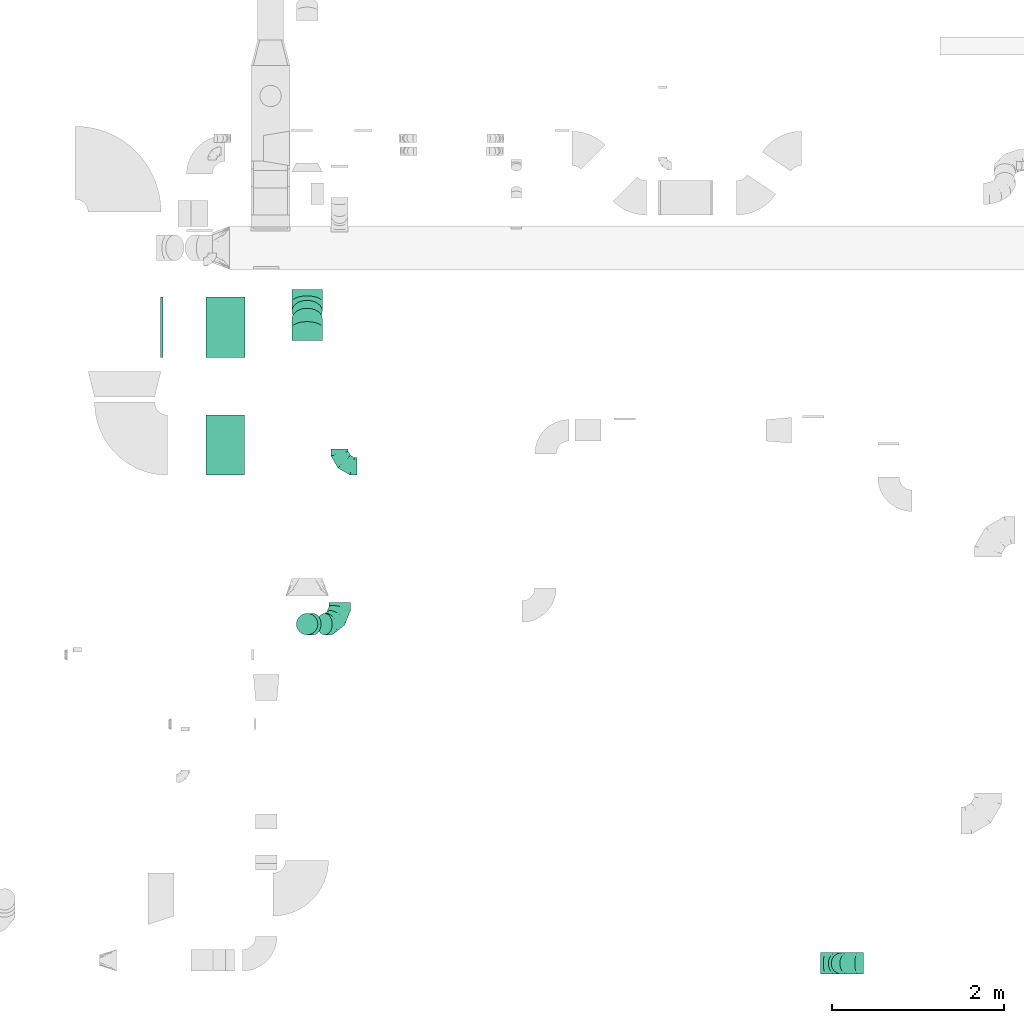
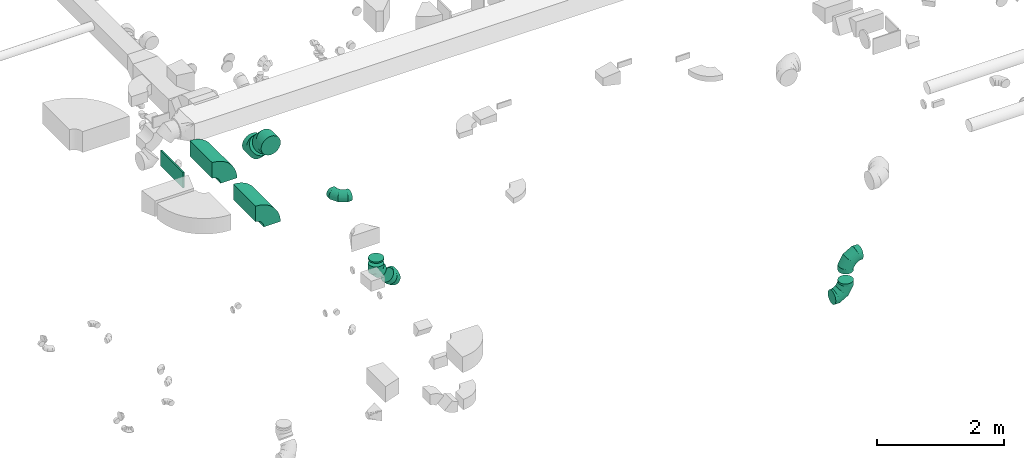
# One storey, part 27 of 62: 11 flow fittings.
"""IFC2X3 building model written with IfcOpenShell, lengths in millimetres."""

from ifc_helpers import new_model, entity, si_unit, converted_unit, derived_unit, direction, frame, frame_2d, origin, origin_2d_with_axis, place, context, subcontext, project, spatial, polyline, circle_curve, parameter, trimmed, segment, composite_curve, rectangle, outline, extrude, faceted_brep, source, transform, mapped, material, type_object, type_shapes, element, save


model = new_model("IFC2X3")

# Units and contexts
model_context = context("Model", 3, precision=0.01, world=origin(), true_north=direction((6.12303176911189e-17, 1.0)))
body_context = subcontext(model_context, "Body", "Model", "MODEL_VIEW")
ifc_project = project(units=[si_unit("LENGTHUNIT", "METRE", prefix="MILLI"), si_unit("AREAUNIT", "SQUARE_METRE"), si_unit("VOLUMEUNIT", "CUBIC_METRE"), converted_unit("PLANEANGLEUNIT", "DEGREE", entity("IfcRatioMeasure", 0.0174532925199433), si_unit("PLANEANGLEUNIT", "RADIAN"), dimensions=[0, 0, 0, 0, 0, 0, 0]), si_unit("MASSUNIT", "GRAM", prefix="KILO"), derived_unit("MASSDENSITYUNIT", [(si_unit("MASSUNIT", "GRAM", prefix="KILO"), 1), (si_unit("LENGTHUNIT", "METRE"), -3)]), derived_unit("MOMENTOFINERTIAUNIT", [(si_unit("LENGTHUNIT", "METRE"), 4)]), si_unit("TIMEUNIT", "SECOND"), si_unit("FREQUENCYUNIT", "HERTZ"), si_unit("THERMODYNAMICTEMPERATUREUNIT", "DEGREE_CELSIUS"), derived_unit("THERMALTRANSMITTANCEUNIT", [(si_unit("MASSUNIT", "GRAM", prefix="KILO"), 1), (si_unit("THERMODYNAMICTEMPERATUREUNIT", "KELVIN"), -1), (si_unit("TIMEUNIT", "SECOND"), -3)]), derived_unit("VOLUMETRICFLOWRATEUNIT", [(si_unit("LENGTHUNIT", "METRE"), 3), (si_unit("TIMEUNIT", "SECOND"), -1)]), derived_unit("MASSFLOWRATEUNIT", [(si_unit("MASSUNIT", "GRAM", prefix="KILO"), 1), (si_unit("TIMEUNIT", "SECOND"), -1)]), derived_unit("ROTATIONALFREQUENCYUNIT", [(si_unit("TIMEUNIT", "SECOND"), -1)]), si_unit("ELECTRICCURRENTUNIT", "AMPERE"), si_unit("ELECTRICVOLTAGEUNIT", "VOLT"), si_unit("POWERUNIT", "WATT"), si_unit("FORCEUNIT", "NEWTON", prefix="KILO"), si_unit("ILLUMINANCEUNIT", "LUX"), si_unit("LUMINOUSFLUXUNIT", "LUMEN"), si_unit("LUMINOUSINTENSITYUNIT", "CANDELA"), derived_unit("USERDEFINED", [(si_unit("MASSUNIT", "GRAM", prefix="KILO"), -1), (si_unit("LENGTHUNIT", "METRE"), -2), (si_unit("TIMEUNIT", "SECOND"), 3), (si_unit("LUMINOUSFLUXUNIT", "LUMEN"), 1)]), derived_unit("LINEARVELOCITYUNIT", [(si_unit("LENGTHUNIT", "METRE"), 1), (si_unit("TIMEUNIT", "SECOND"), -1)]), si_unit("PRESSUREUNIT", "PASCAL"), derived_unit("USERDEFINED", [(si_unit("LENGTHUNIT", "METRE"), -2), (si_unit("MASSUNIT", "GRAM", prefix="KILO"), 1), (si_unit("TIMEUNIT", "SECOND"), -2)]), derived_unit("LINEARFORCEUNIT", [(si_unit("MASSUNIT", "GRAM", prefix="KILO"), 1), (si_unit("LENGTHUNIT", "METRE"), 1), (si_unit("TIMEUNIT", "SECOND"), -2), (si_unit("LENGTHUNIT", "METRE"), -1)]), derived_unit("PLANARFORCEUNIT", [(si_unit("MASSUNIT", "GRAM", prefix="KILO"), 1), (si_unit("LENGTHUNIT", "METRE"), 1), (si_unit("TIMEUNIT", "SECOND"), -2), (si_unit("LENGTHUNIT", "METRE"), -2)])], contexts=[model_context])

# Site, building, storey
site_placement = place(None, origin())
site = spatial("IfcSite", under=ifc_project, at=site_placement, CompositionType="ELEMENT")
building_placement = place(site_placement, origin())
building = spatial("IfcBuilding", under=site, at=building_placement, CompositionType="ELEMENT")
storey_placement = place(building_placement, frame((0.0, 0.0, 24000.0)))
storey = spatial("IfcBuildingStorey", under=building, at=storey_placement, CompositionType="ELEMENT", Elevation=24000.0)

# Flow fittings
ifc_material = material()
duct_fitting_type_1 = type_object("IfcDuctFittingType", PredefinedType="NOTDEFINED", material=ifc_material)
shared_shape_1 = source(origin(), body_context, "Body", "SweptSolid", [
    extrude(rectangle(XDim=26.096000000006, YDim=700.0, at=origin_2d_with_axis()), frame((6.95, 0.0, -150.0)), (0.0, 0.0, 1.0), 300.0),
])
type_shapes(duct_fitting_type_1, [shared_shape_1])
flow_fitting_1_placement = place(storey_placement, frame((38820.62, 8000.31, 3550.0), z_axis=(0.0, 0.0, -1.0), x_axis=(1.0, 0.0, 0.0)))
element("IfcFlowFitting", 1, at=flow_fitting_1_placement, inside=storey, type_object=duct_fitting_type_1, material=ifc_material, context=body_context, shape_type="MappedRepresentation", body=[
    mapped(shared_shape_1, transform((0.0, 0.0, 0.0), scale=1.0)),
])
duct_fitting_type_2 = type_object("IfcDuctFittingType", PredefinedType="NOTDEFINED", material=ifc_material)
shared_shape_2 = source(origin(), body_context, "Body", "Brep", [
    faceted_brep([(-250.0, 0.0, -125.0), (-250.0, -32.35, -120.74), (-250.0, -62.5, -108.25), (-250.0, -88.39, -88.39), (-250.0, -108.25, -62.5), (-250.0, -120.74, -32.35), (-250.0, -125.0, 0.0), (-250.0, -120.74, 32.35), (-250.0, -108.25, 62.5), (-250.0, -88.39, 88.39), (-250.0, -62.5, 108.25), (-250.0, -32.35, 120.74), (-250.0, 0.0, 125.0), (-250.0, 32.35, 120.74), (-250.0, 62.5, 108.25), (-250.0, 88.39, 88.39), (-250.0, 108.25, 62.5), (-250.0, 120.74, 32.35), (-250.0, 125.0, 0.0), (-250.0, 120.74, -32.35), (-250.0, 108.25, -62.5), (-250.0, 88.39, -88.39), (-250.0, 62.5, -108.25), (-250.0, 32.35, -120.74), (-191.68, 32.35, 120.74), (-199.76, 62.5, 108.25), (-183.01, 0.0, 125.0), (-206.7, 88.39, 88.39), (-215.37, 120.74, 32.35), (-216.51, 125.0, 0.0), (-212.02, 108.25, 62.5), (-212.02, 108.25, -62.5), (-206.7, 88.39, -88.39), (-215.37, 120.74, -32.35), (-191.68, 32.35, -120.74), (-183.01, 0.0, -125.0), (-199.76, 62.5, -108.25), (-174.34, -32.35, -120.74), (-166.27, -62.5, -108.25), (-159.33, -88.39, -88.39), (-154.01, -108.25, -62.5), (-150.66, -120.74, -32.35), (-149.52, -125.0, 0.0), (-150.66, -120.74, 32.35), (-154.01, -108.25, 62.5), (-159.33, -88.39, 88.39), (-166.27, -62.5, 108.25), (-174.34, -32.35, 120.74), (-90.67, 90.67, 120.74), (-112.74, 112.74, 108.25), (-66.99, 66.99, 125.0), (-131.69, 131.69, 88.39), (-146.23, 146.23, 62.5), (-155.38, 155.38, 32.35), (-158.49, 158.49, 0.0), (-155.38, 155.38, -32.35), (-146.23, 146.23, -62.5), (-131.69, 131.69, -88.39), (-90.67, 90.67, -120.74), (-66.99, 66.99, -125.0), (-112.74, 112.74, -108.25), (-43.3, 43.3, -120.74), (-21.23, 21.23, -108.25), (-2.28, 2.28, -88.39), (12.26, -12.26, -62.5), (21.4, -21.4, -32.35), (24.52, -24.52, 0.0), (21.4, -21.4, 32.35), (12.26, -12.26, 62.5), (-2.28, 2.28, 88.39), (-21.23, 21.23, 108.25), (-43.3, 43.3, 120.74), (-32.35, 191.68, 120.74), (-62.5, 199.76, 108.25), (0.0, 183.01, 125.0), (-88.39, 206.7, 88.39), (-108.25, 212.02, 62.5), (-120.74, 215.37, 32.35), (-125.0, 216.51, 0.0), (-120.74, 215.37, -32.35), (-108.25, 212.02, -62.5), (-88.39, 206.7, -88.39), (-32.35, 191.68, -120.74), (0.0, 183.01, -125.0), (-62.5, 199.76, -108.25), (32.35, 174.34, -120.74), (62.5, 166.27, -108.25), (88.39, 159.33, -88.39), (108.25, 154.01, -62.5), (120.74, 150.66, -32.35), (125.0, 149.52, 0.0), (120.74, 150.66, 32.35), (108.25, 154.01, 62.5), (88.39, 159.33, 88.39), (62.5, 166.27, 108.25), (32.35, 174.34, 120.74), (-32.35, 250.0, -120.74), (-62.5, 250.0, -108.25), (-88.39, 250.0, -88.39), (-108.25, 250.0, -62.5), (-120.74, 250.0, -32.35), (-125.0, 250.0, 0.0), (-120.74, 250.0, 32.35), (-108.25, 250.0, 62.5), (-88.39, 250.0, 88.39), (-62.5, 250.0, 108.25), (-32.35, 250.0, 120.74), (0.0, 250.0, 125.0), (32.35, 250.0, 120.74), (62.5, 250.0, 108.25), (88.39, 250.0, 88.39), (108.25, 250.0, 62.5), (120.74, 250.0, 32.35), (125.0, 250.0, 0.0), (120.74, 250.0, -32.35), (108.25, 250.0, -62.5), (88.39, 250.0, -88.39), (62.5, 250.0, -108.25), (32.35, 250.0, -120.74), (0.0, 250.0, -125.0)], [[[0, 1, 2, 3, 4, 5, 6, 7, 8, 9, 10, 11, 12, 13, 14, 15, 16, 17, 18, 19, 20, 21, 22, 23]], [[24, 25, 14, 13]], [[26, 24, 13, 12]], [[14, 25, 27, 15]], [[28, 29, 18, 17]], [[30, 28, 17, 16]], [[15, 27, 30, 16]], [[20, 31, 32, 21]], [[33, 31, 20, 19]], [[18, 29, 33, 19]], [[34, 35, 0, 23]], [[36, 34, 23, 22]], [[21, 32, 36, 22]], [[1, 0, 35, 37]], [[2, 1, 37, 38]], [[38, 39, 3, 2]], [[5, 4, 40, 41]], [[6, 5, 41, 42]], [[39, 40, 4, 3]], [[6, 42, 43, 7]], [[7, 43, 44, 8]], [[8, 44, 45, 9]], [[9, 45, 46, 10]], [[10, 46, 47, 11]], [[26, 12, 11, 47]], [[48, 49, 25, 24]], [[50, 48, 24, 26]], [[27, 25, 49, 51]], [[52, 53, 28, 30]], [[51, 52, 30, 27]], [[29, 28, 53, 54]], [[55, 56, 31, 33]], [[54, 55, 33, 29]], [[32, 31, 56, 57]], [[58, 59, 35, 34]], [[60, 58, 34, 36]], [[57, 60, 36, 32]], [[37, 35, 59, 61]], [[38, 37, 61, 62]], [[39, 38, 62, 63]], [[41, 40, 64, 65]], [[42, 41, 65, 66]], [[63, 64, 40, 39]], [[43, 42, 66, 67]], [[44, 43, 67, 68]], [[68, 69, 45, 44]], [[46, 45, 69, 70]], [[47, 46, 70, 71]], [[26, 47, 71, 50]], [[72, 73, 49, 48]], [[74, 72, 48, 50]], [[51, 49, 73, 75]], [[76, 77, 53, 52]], [[75, 76, 52, 51]], [[54, 53, 77, 78]], [[79, 80, 56, 55]], [[78, 79, 55, 54]], [[57, 56, 80, 81]], [[82, 83, 59, 58]], [[84, 82, 58, 60]], [[81, 84, 60, 57]], [[61, 59, 83, 85]], [[62, 61, 85, 86]], [[63, 62, 86, 87]], [[65, 64, 88, 89]], [[66, 65, 89, 90]], [[87, 88, 64, 63]], [[67, 66, 90, 91]], [[68, 67, 91, 92]], [[92, 93, 69, 68]], [[70, 69, 93, 94]], [[71, 70, 94, 95]], [[50, 71, 95, 74]], [[96, 97, 98, 99, 100, 101, 102, 103, 104, 105, 106, 107, 108, 109, 110, 111, 112, 113, 114, 115, 116, 117, 118, 119]], [[72, 74, 107, 106]], [[73, 72, 106, 105]], [[75, 73, 105, 104]], [[77, 76, 103, 102]], [[78, 77, 102, 101]], [[75, 104, 103, 76]], [[78, 101, 100, 79]], [[79, 100, 99, 80]], [[80, 99, 98, 81]], [[84, 97, 96, 82]], [[82, 96, 119, 83]], [[84, 81, 98, 97]], [[83, 119, 118, 85]], [[85, 118, 117, 86]], [[116, 87, 86, 117]], [[88, 115, 114, 89]], [[89, 114, 113, 90]], [[115, 88, 87, 116]], [[91, 90, 113, 112]], [[92, 91, 112, 111]], [[111, 110, 93, 92]], [[95, 94, 109, 108]], [[74, 95, 108, 107]], [[110, 109, 94, 93]]]),
])
type_shapes(duct_fitting_type_2, [shared_shape_2])
for number, where, z_axis, x_axis in (
    (2, (40901.66, 4543.59, 2775.0), (0.707106781186431, 0.0, 0.707106781186664), (0.707106781186664, 0.0, -0.707106781186431)),
    (3, (46747.3, 593.17, 2900.0), (0.0, -1.0, 0.0), (1.0, 0.0, 0.0)),
    (4, (46747.3, 593.17, 3590.0), (0.0, 1.0, 0.0), (0.0, 0.0, 1.0)),
):
    element("IfcFlowFitting", number, at=place(storey_placement, frame(where, z_axis=z_axis, x_axis=x_axis)), inside=storey, type_object=duct_fitting_type_2, material=ifc_material, context=body_context, shape_type="MappedRepresentation", body=[
        mapped(shared_shape_2, transform((0.0, 0.0, 0.0), scale=1.0)),
    ])
duct_fitting_type_3 = type_object("IfcDuctFittingType", PredefinedType="NOTDEFINED", material=ifc_material)
shared_shape_3 = source(origin(), body_context, "Body", "Brep", [
    faceted_brep([(20.0, 0.0, -125.0), (20.0, 32.35, -120.74), (20.0, 62.5, -108.25), (20.0, 88.39, -88.39), (20.0, 108.25, -62.5), (20.0, 120.74, -32.35), (20.0, 125.0, 0.0), (20.0, 120.74, 32.35), (20.0, 108.25, 62.5), (20.0, 88.39, 88.39), (20.0, 62.5, 108.25), (20.0, 32.35, 120.74), (20.0, 0.0, 125.0), (20.0, -32.35, 120.74), (20.0, -62.5, 108.25), (20.0, -88.39, 88.39), (20.0, -108.25, 62.5), (20.0, -120.74, 32.35), (20.0, -125.0, 0.0), (20.0, -120.74, -32.35), (20.0, -108.25, -62.5), (20.0, -88.39, -88.39), (20.0, -62.5, -108.25), (20.0, -32.35, -120.74), (0.0, 0.0, 125.0), (-6.1, 0.0, 125.0), (-6.1, -32.35, 120.74), (0.0, -32.35, 120.74), (-6.1, -62.5, 108.25), (0.0, -62.5, 108.25), (0.0, -88.39, 88.39), (-6.1, -88.39, 88.39), (0.0, -108.25, 62.5), (-6.1, -108.25, 62.5), (-6.1, -120.74, 32.35), (0.0, -120.74, 32.35), (-6.1, -125.0, 0.0), (0.0, -125.0, 0.0), (-6.1, -120.74, -32.35), (0.0, -120.74, -32.35), (-6.1, -108.25, -62.5), (0.0, -108.25, -62.5), (0.0, -88.39, -88.39), (-6.1, -88.39, -88.39), (0.0, -62.5, -108.25), (-6.1, -62.5, -108.25), (-6.1, -32.35, -120.74), (0.0, -32.35, -120.74), (-6.1, 0.0, -125.0), (0.0, 0.0, -125.0), (-6.1, 32.35, -120.74), (0.0, 32.35, -120.74), (-6.1, 62.5, -108.25), (0.0, 62.5, -108.25), (0.0, 88.39, -88.39), (-6.1, 88.39, -88.39), (0.0, 108.25, -62.5), (-6.1, 108.25, -62.5), (-6.1, 120.74, -32.35), (0.0, 120.74, -32.35), (-6.1, 125.0, 0.0), (0.0, 125.0, 0.0), (-6.1, 120.74, 32.35), (0.0, 120.74, 32.35), (-6.1, 108.25, 62.5), (0.0, 108.25, 62.5), (0.0, 88.39, 88.39), (-6.1, 88.39, 88.39), (0.0, 62.5, 108.25), (-6.1, 62.5, 108.25), (-6.1, 32.35, 120.74), (0.0, 32.35, 120.74)], [[[0, 1, 2, 3, 4, 5, 6, 7, 8, 9, 10, 11, 12, 13, 14, 15, 16, 17, 18, 19, 20, 21, 22, 23]], [[13, 12, 24, 25, 26, 27]], [[14, 13, 27, 26, 28, 29]], [[30, 15, 14, 29, 28, 31]], [[17, 16, 32, 33, 34, 35]], [[18, 17, 35, 34, 36, 37]], [[32, 16, 15, 30, 31, 33]], [[19, 18, 37, 36, 38, 39]], [[20, 19, 39, 38, 40, 41]], [[42, 21, 20, 41, 40, 43]], [[23, 22, 44, 45, 46, 47]], [[0, 23, 47, 46, 48, 49]], [[44, 22, 21, 42, 43, 45]], [[1, 0, 49, 48, 50, 51]], [[2, 1, 51, 50, 52, 53]], [[54, 3, 2, 53, 52, 55]], [[5, 4, 56, 57, 58, 59]], [[6, 5, 59, 58, 60, 61]], [[56, 4, 3, 54, 55, 57]], [[7, 6, 61, 60, 62, 63]], [[8, 7, 63, 62, 64, 65]], [[66, 9, 8, 65, 64, 67]], [[11, 10, 68, 69, 70, 71]], [[12, 11, 71, 70, 25, 24]], [[68, 10, 9, 66, 67, 69]], [[46, 45, 43, 40, 38, 36, 34, 33, 31, 28, 26, 25, 70, 69, 67, 64, 62, 60, 58, 57, 55, 52, 50, 48]]]),
])
type_shapes(duct_fitting_type_3, [shared_shape_3])
flow_fitting_2_placement = place(storey_placement, frame((40520.63, 4543.59, 3350.0), z_axis=(0.0, 1.0, 0.0), x_axis=(0.0, 0.0, -1.0)))
element("IfcFlowFitting", 5, at=flow_fitting_2_placement, inside=storey, type_object=duct_fitting_type_3, material=ifc_material, context=body_context, shape_type="MappedRepresentation", body=[
    mapped(shared_shape_3, transform((0.0, 0.0, 0.0), scale=1.0)),
])
duct_fitting_type_4 = type_object("IfcDuctFittingType", PredefinedType="NOTDEFINED", material=ifc_material)
shared_shape_4 = source(origin(), body_context, "Body", "Brep", [
    faceted_brep([(-200.0, 0.0, -100.0), (-200.0, -25.88, -96.59), (-200.0, -50.0, -86.6), (-200.0, -70.71, -70.71), (-200.0, -86.6, -50.0), (-200.0, -96.59, -25.88), (-200.0, -100.0, 0.0), (-200.0, -96.59, 25.88), (-200.0, -86.6, 50.0), (-200.0, -70.71, 70.71), (-200.0, -50.0, 86.6), (-200.0, -25.88, 96.59), (-200.0, 0.0, 100.0), (-200.0, 25.88, 96.59), (-200.0, 50.0, 86.6), (-200.0, 70.71, 70.71), (-200.0, 86.6, 50.0), (-200.0, 96.59, 25.88), (-200.0, 100.0, 0.0), (-200.0, 96.59, -25.88), (-200.0, 86.6, -50.0), (-200.0, 70.71, -70.71), (-200.0, 50.0, -86.6), (-200.0, 25.88, -96.59), (-153.35, 25.88, 96.59), (-159.81, 50.0, 86.6), (-146.41, 0.0, 100.0), (-165.36, 70.71, 70.71), (-172.29, 96.59, 25.88), (-173.21, 100.0, 0.0), (-169.62, 86.6, 50.0), (-169.62, 86.6, -50.0), (-165.36, 70.71, -70.71), (-172.29, 96.59, -25.88), (-153.35, 25.88, -96.59), (-146.41, 0.0, -100.0), (-159.81, 50.0, -86.6), (-139.48, -25.88, -96.59), (-133.01, -50.0, -86.6), (-127.46, -70.71, -70.71), (-123.21, -86.6, -50.0), (-120.53, -96.59, -25.88), (-119.62, -100.0, 0.0), (-120.53, -96.59, 25.88), (-123.21, -86.6, 50.0), (-127.46, -70.71, 70.71), (-133.01, -50.0, 86.6), (-139.48, -25.88, 96.59), (-72.54, 72.54, 96.59), (-90.19, 90.19, 86.6), (-53.59, 53.59, 100.0), (-105.35, 105.35, 70.71), (-116.99, 116.99, 50.0), (-124.3, 124.3, 25.88), (-126.79, 126.79, 0.0), (-124.3, 124.3, -25.88), (-116.99, 116.99, -50.0), (-105.35, 105.35, -70.71), (-72.54, 72.54, -96.59), (-53.59, 53.59, -100.0), (-90.19, 90.19, -86.6), (-34.64, 34.64, -96.59), (-16.99, 16.99, -86.6), (-1.83, 1.83, -70.71), (9.81, -9.81, -50.0), (17.12, -17.12, -25.88), (19.62, -19.62, 0.0), (17.12, -17.12, 25.88), (9.81, -9.81, 50.0), (-1.83, 1.83, 70.71), (-16.99, 16.99, 86.6), (-34.64, 34.64, 96.59), (-25.88, 153.35, 96.59), (-50.0, 159.81, 86.6), (0.0, 146.41, 100.0), (-70.71, 165.36, 70.71), (-86.6, 169.62, 50.0), (-96.59, 172.29, 25.88), (-100.0, 173.21, 0.0), (-96.59, 172.29, -25.88), (-86.6, 169.62, -50.0), (-70.71, 165.36, -70.71), (-25.88, 153.35, -96.59), (0.0, 146.41, -100.0), (-50.0, 159.81, -86.6), (25.88, 139.48, -96.59), (50.0, 133.01, -86.6), (70.71, 127.46, -70.71), (86.6, 123.21, -50.0), (96.59, 120.53, -25.88), (100.0, 119.62, 0.0), (96.59, 120.53, 25.88), (86.6, 123.21, 50.0), (70.71, 127.46, 70.71), (50.0, 133.01, 86.6), (25.88, 139.48, 96.59), (-25.88, 200.0, -96.59), (-50.0, 200.0, -86.6), (-70.71, 200.0, -70.71), (-86.6, 200.0, -50.0), (-96.59, 200.0, -25.88), (-100.0, 200.0, 0.0), (-96.59, 200.0, 25.88), (-86.6, 200.0, 50.0), (-70.71, 200.0, 70.71), (-50.0, 200.0, 86.6), (-25.88, 200.0, 96.59), (0.0, 200.0, 100.0), (25.88, 200.0, 96.59), (50.0, 200.0, 86.6), (70.71, 200.0, 70.71), (86.6, 200.0, 50.0), (96.59, 200.0, 25.88), (100.0, 200.0, 0.0), (96.59, 200.0, -25.88), (86.6, 200.0, -50.0), (70.71, 200.0, -70.71), (50.0, 200.0, -86.6), (25.88, 200.0, -96.59), (0.0, 200.0, -100.0)], [[[0, 1, 2, 3, 4, 5, 6, 7, 8, 9, 10, 11, 12, 13, 14, 15, 16, 17, 18, 19, 20, 21, 22, 23]], [[24, 25, 14, 13]], [[26, 24, 13, 12]], [[14, 25, 27, 15]], [[28, 29, 18, 17]], [[30, 28, 17, 16]], [[15, 27, 30, 16]], [[20, 31, 32, 21]], [[33, 31, 20, 19]], [[18, 29, 33, 19]], [[34, 35, 0, 23]], [[36, 34, 23, 22]], [[32, 36, 22, 21]], [[1, 0, 35, 37]], [[2, 1, 37, 38]], [[38, 39, 3, 2]], [[5, 4, 40, 41]], [[6, 5, 41, 42]], [[39, 40, 4, 3]], [[6, 42, 43, 7]], [[7, 43, 44, 8]], [[8, 44, 45, 9]], [[9, 45, 46, 10]], [[10, 46, 47, 11]], [[26, 12, 11, 47]], [[48, 49, 25, 24]], [[50, 48, 24, 26]], [[27, 25, 49, 51]], [[52, 53, 28, 30]], [[51, 52, 30, 27]], [[29, 28, 53, 54]], [[55, 56, 31, 33]], [[54, 55, 33, 29]], [[32, 31, 56, 57]], [[58, 59, 35, 34]], [[60, 58, 34, 36]], [[57, 60, 36, 32]], [[37, 35, 59, 61]], [[38, 37, 61, 62]], [[39, 38, 62, 63]], [[41, 40, 64, 65]], [[42, 41, 65, 66]], [[63, 64, 40, 39]], [[43, 42, 66, 67]], [[44, 43, 67, 68]], [[68, 69, 45, 44]], [[46, 45, 69, 70]], [[47, 46, 70, 71]], [[26, 47, 71, 50]], [[72, 73, 49, 48]], [[74, 72, 48, 50]], [[51, 49, 73, 75]], [[76, 77, 53, 52]], [[75, 76, 52, 51]], [[54, 53, 77, 78]], [[79, 80, 56, 55]], [[78, 79, 55, 54]], [[57, 56, 80, 81]], [[82, 83, 59, 58]], [[84, 82, 58, 60]], [[81, 84, 60, 57]], [[61, 59, 83, 85]], [[62, 61, 85, 86]], [[63, 62, 86, 87]], [[65, 64, 88, 89]], [[66, 65, 89, 90]], [[87, 88, 64, 63]], [[67, 66, 90, 91]], [[68, 67, 91, 92]], [[92, 93, 69, 68]], [[70, 69, 93, 94]], [[71, 70, 94, 95]], [[50, 71, 95, 74]], [[96, 97, 98, 99, 100, 101, 102, 103, 104, 105, 106, 107, 108, 109, 110, 111, 112, 113, 114, 115, 116, 117, 118, 119]], [[72, 74, 107, 106]], [[73, 72, 106, 105]], [[75, 73, 105, 104]], [[102, 101, 78, 77]], [[103, 102, 77, 76]], [[75, 104, 103, 76]], [[78, 101, 100, 79]], [[79, 100, 99, 80]], [[80, 99, 98, 81]], [[84, 97, 96, 82]], [[82, 96, 119, 83]], [[84, 81, 98, 97]], [[118, 117, 86, 85]], [[119, 118, 85, 83]], [[116, 87, 86, 117]], [[88, 115, 114, 89]], [[89, 114, 113, 90]], [[115, 88, 87, 116]], [[91, 90, 113, 112]], [[92, 91, 112, 111]], [[111, 110, 93, 92]], [[95, 94, 109, 108]], [[74, 95, 108, 107]], [[110, 109, 94, 93]]]),
])
type_shapes(duct_fitting_type_4, [shared_shape_4])
flow_fitting_3_placement = place(storey_placement, frame((40899.04, 6381.51, 3240.0), z_axis=(0.0, 0.0, 1.0), x_axis=(0.0, -1.0, 0.0)))
element("IfcFlowFitting", 6, at=flow_fitting_3_placement, inside=storey, type_object=duct_fitting_type_4, material=ifc_material, context=body_context, shape_type="MappedRepresentation", body=[
    mapped(shared_shape_4, transform((0.0, 0.0, 0.0), scale=1.0)),
])
duct_fitting_type_5 = type_object("IfcDuctFittingType", PredefinedType="NOTDEFINED", material=ifc_material)
shared_shape_5 = source(origin(), body_context, "Body", "Brep", [
    faceted_brep([(-103.55, 0.0, -125.0), (-103.55, -32.35, -120.74), (-103.55, -62.5, -108.25), (-103.55, -88.39, -88.39), (-103.55, -108.25, -62.5), (-103.55, -120.74, -32.35), (-103.55, -125.0, 0.0), (-103.55, -120.74, 32.35), (-103.55, -108.25, 62.5), (-103.55, -88.39, 88.39), (-103.55, -62.5, 108.25), (-103.55, -32.35, 120.74), (-103.55, 0.0, 125.0), (-103.55, 32.35, 120.74), (-103.55, 62.5, 108.25), (-103.55, 88.39, 88.39), (-103.55, 108.25, 62.5), (-103.55, 120.74, 32.35), (-103.55, 125.0, 0.0), (-103.55, 120.74, -32.35), (-103.55, 108.25, -62.5), (-103.55, 88.39, -88.39), (-103.55, 62.5, -108.25), (-103.55, 32.35, -120.74), (-13.4, 32.35, 120.74), (-25.89, 62.5, 108.25), (0.0, 0.0, 125.0), (-36.61, 88.39, 88.39), (-44.84, 108.25, 62.5), (-50.01, 120.74, 32.35), (-51.78, 125.0, 0.0), (-50.01, 120.74, -32.35), (-44.84, 108.25, -62.5), (-36.61, 88.39, -88.39), (-13.4, 32.35, -120.74), (0.0, 0.0, -125.0), (-25.89, 62.5, -108.25), (13.4, -32.35, -120.74), (25.89, -62.5, -108.25), (36.61, -88.39, -88.39), (44.84, -108.25, -62.5), (50.01, -120.74, -32.35), (51.78, -125.0, 0.0), (50.01, -120.74, 32.35), (44.84, -108.25, 62.5), (36.61, -88.39, 88.39), (25.89, -62.5, 108.25), (13.4, -32.35, 120.74), (73.22, 73.22, 125.0), (50.35, 96.1, 120.74), (29.03, 117.42, 108.25), (10.72, 135.72, 88.39), (-3.32, 149.77, 62.5), (-12.15, 158.6, 32.35), (-15.17, 161.61, 0.0), (-12.15, 158.6, -32.35), (-3.32, 149.77, -62.5), (10.72, 135.72, -88.39), (29.03, 117.42, -108.25), (50.35, 96.1, -120.74), (73.22, 73.22, -125.0), (96.1, 50.35, -120.74), (117.42, 29.03, -108.25), (135.72, 10.72, -88.39), (149.77, -3.32, -62.5), (158.6, -12.15, -32.35), (161.61, -15.17, 0.0), (158.6, -12.15, 32.35), (149.77, -3.32, 62.5), (135.72, 10.72, 88.39), (117.42, 29.03, 108.25), (96.1, 50.35, 120.74)], [[[0, 1, 2, 3, 4, 5, 6, 7, 8, 9, 10, 11, 12, 13, 14, 15, 16, 17, 18, 19, 20, 21, 22, 23]], [[24, 25, 14, 13]], [[26, 24, 13, 12]], [[14, 25, 27, 15]], [[28, 29, 17, 16]], [[28, 16, 15, 27]], [[30, 18, 17, 29]], [[31, 32, 20, 19]], [[30, 31, 19, 18]], [[32, 33, 21, 20]], [[34, 35, 0, 23]], [[36, 34, 23, 22]], [[33, 36, 22, 21]], [[1, 0, 35, 37]], [[2, 1, 37, 38]], [[38, 39, 3, 2]], [[5, 4, 40, 41]], [[6, 5, 41, 42]], [[39, 40, 4, 3]], [[6, 42, 43, 7]], [[7, 43, 44, 8]], [[8, 44, 45, 9]], [[9, 45, 46, 10]], [[10, 46, 47, 11]], [[26, 12, 11, 47]], [[24, 26, 48, 49]], [[25, 24, 49, 50]], [[27, 25, 50, 51]], [[29, 28, 52, 53]], [[30, 29, 53, 54]], [[51, 52, 28, 27]], [[30, 54, 55, 31]], [[31, 55, 56, 32]], [[57, 33, 32, 56]], [[36, 58, 59, 34]], [[34, 59, 60, 35]], [[58, 36, 33, 57]], [[35, 60, 61, 37]], [[37, 61, 62, 38]], [[63, 39, 38, 62]], [[40, 64, 65, 41]], [[41, 65, 66, 42]], [[64, 40, 39, 63]], [[43, 42, 66, 67]], [[44, 43, 67, 68]], [[68, 69, 45, 44]], [[47, 46, 70, 71]], [[26, 47, 71, 48]], [[69, 70, 46, 45]], [[59, 58, 57, 56, 55, 54, 53, 52, 51, 50, 49, 48, 71, 70, 69, 68, 67, 66, 65, 64, 63, 62, 61, 60]]]),
])
type_shapes(duct_fitting_type_5, [shared_shape_5])
flow_fitting_4_placement = place(storey_placement, frame((40520.63, 4543.59, 3156.04), z_axis=(0.0, 1.0, 0.0), x_axis=(-0.707106781186664, 0.0, 0.707106781186431)))
element("IfcFlowFitting", 7, at=flow_fitting_4_placement, inside=storey, type_object=duct_fitting_type_5, material=ifc_material, context=body_context, shape_type="MappedRepresentation", body=[
    mapped(shared_shape_5, transform((0.0, 0.0, 0.0), scale=1.0)),
])
duct_fitting_type_6 = type_object("IfcDuctFittingType", PredefinedType="NOTDEFINED", material=ifc_material)
shared_shape_6 = source(origin(), body_context, "Body", "Brep", [
    faceted_brep([(-147.05, 0.0, -177.5), (-147.05, -45.94, -171.45), (-147.05, -88.75, -153.72), (-147.05, -125.51, -125.51), (-147.05, -153.72, -88.75), (-147.05, -171.45, -45.94), (-147.05, -177.5, 0.0), (-147.05, -171.45, 45.94), (-147.05, -153.72, 88.75), (-147.05, -125.51, 125.51), (-147.05, -88.75, 153.72), (-147.05, -45.94, 171.45), (-147.05, 0.0, 177.5), (-147.05, 45.94, 171.45), (-147.05, 88.75, 153.72), (-147.05, 125.51, 125.51), (-147.05, 153.72, 88.75), (-147.05, 171.45, 45.94), (-147.05, 177.5, 0.0), (-147.05, 171.45, -45.94), (-147.05, 153.72, -88.75), (-147.05, 125.51, -125.51), (-147.05, 88.75, -153.72), (-147.05, 45.94, -171.45), (-16.36, 39.5, 173.05), (-31.9, 77.01, 159.92), (0.0, 0.0, 177.5), (-45.84, 110.67, 138.78), (-57.48, 138.78, 110.67), (-66.24, 159.92, 77.01), (-71.68, 173.05, 39.5), (-73.52, 177.5, 0.0), (-66.24, 159.92, -77.01), (-57.48, 138.78, -110.67), (-71.68, 173.05, -39.5), (-45.84, 110.67, -138.78), (-31.9, 77.01, -159.92), (-16.36, 39.5, -173.05), (0.0, 0.0, -177.5), (16.36, -39.5, -173.05), (31.9, -77.01, -159.92), (45.84, -110.67, -138.78), (57.48, -138.78, -110.67), (66.24, -159.92, -77.01), (71.68, -173.05, -39.5), (73.52, -177.5, 0.0), (71.68, -173.05, 39.5), (66.24, -159.92, 77.01), (57.48, -138.78, 110.67), (45.84, -110.67, 138.78), (31.9, -77.01, 159.92), (16.36, -39.5, 173.05), (103.98, 103.98, 177.5), (71.49, 136.46, 171.45), (41.22, 166.73, 153.72), (15.23, 192.73, 125.51), (-4.72, 212.67, 88.75), (-17.26, 225.21, 45.94), (-21.53, 229.49, 0.0), (-17.26, 225.21, -45.94), (-4.72, 212.67, -88.75), (15.23, 192.73, -125.51), (41.22, 166.73, -153.72), (71.49, 136.46, -171.45), (103.98, 103.98, -177.5), (136.46, 71.49, -171.45), (166.73, 41.22, -153.72), (192.73, 15.23, -125.51), (212.67, -4.72, -88.75), (225.21, -17.26, -45.94), (229.49, -21.53, 0.0), (225.21, -17.26, 45.94), (212.67, -4.72, 88.75), (192.73, 15.23, 125.51), (166.73, 41.22, 153.72), (136.46, 71.49, 171.45)], [[[0, 1, 2, 3, 4, 5, 6, 7, 8, 9, 10, 11, 12, 13, 14, 15, 16, 17, 18, 19, 20, 21, 22, 23]], [[24, 25, 13]], [[26, 24, 12]], [[12, 24, 13]], [[14, 27, 15]], [[14, 13, 25]], [[27, 14, 25]], [[28, 29, 16]], [[30, 31, 18]], [[29, 30, 17]], [[15, 28, 16]], [[16, 29, 17]], [[30, 18, 17]], [[28, 15, 27]], [[32, 33, 20]], [[34, 32, 19]], [[31, 34, 18]], [[18, 34, 19]], [[32, 20, 19]], [[33, 21, 20]], [[35, 36, 22]], [[37, 38, 0]], [[36, 37, 23]], [[21, 35, 22]], [[22, 36, 23]], [[37, 0, 23]], [[35, 21, 33]], [[1, 39, 40]], [[2, 40, 41]], [[38, 39, 0]], [[0, 39, 1]], [[40, 2, 1]], [[41, 3, 2]], [[4, 42, 43]], [[43, 44, 5]], [[45, 6, 44]], [[3, 42, 4]], [[4, 43, 5]], [[44, 6, 5]], [[42, 3, 41]], [[6, 45, 46]], [[7, 46, 47]], [[6, 46, 7]], [[8, 48, 9]], [[8, 7, 47]], [[48, 8, 47]], [[10, 49, 50]], [[11, 50, 51]], [[12, 51, 26]], [[9, 49, 10]], [[10, 50, 11]], [[51, 12, 11]], [[49, 9, 48]], [[24, 52, 53]], [[25, 53, 54]], [[24, 26, 52]], [[27, 25, 54]], [[24, 53, 25]], [[54, 55, 27]], [[28, 55, 56]], [[29, 56, 57]], [[30, 57, 58]], [[29, 28, 56]], [[31, 30, 58]], [[29, 57, 30]], [[55, 28, 27]], [[59, 60, 32]], [[58, 59, 34]], [[34, 31, 58]], [[33, 32, 60]], [[34, 59, 32]], [[60, 61, 33]], [[35, 61, 62]], [[36, 62, 63]], [[37, 63, 64]], [[36, 35, 62]], [[38, 37, 64]], [[36, 63, 37]], [[61, 35, 33]], [[39, 64, 65]], [[40, 65, 66]], [[38, 64, 39]], [[40, 39, 65]], [[41, 40, 66]], [[66, 67, 41]], [[42, 67, 68]], [[43, 68, 69]], [[44, 69, 70]], [[42, 68, 43]], [[44, 43, 69]], [[45, 44, 70]], [[67, 42, 41]], [[46, 70, 71]], [[47, 71, 72]], [[45, 70, 46]], [[46, 71, 47]], [[72, 48, 47]], [[72, 73, 48]], [[49, 73, 74]], [[50, 74, 75]], [[51, 75, 52]], [[49, 74, 50]], [[50, 75, 51]], [[52, 26, 51]], [[73, 49, 48]], [[63, 62, 61, 60, 59, 58, 57, 56, 55, 54, 53, 52, 75, 74, 73, 72, 71, 70, 69, 68, 67, 66, 65, 64]]]),
])
type_shapes(duct_fitting_type_6, [shared_shape_6])
for number, where, z_axis, x_axis in (
    (8, (40520.63, 7991.81, 3500.0), (-1.0, 0.0, 0.0), (0.0, 1.0, 0.0)),
    (9, (40520.63, 8291.81, 3200.0), (1.0, 0.0, 0.0), (0.0, 0.70710679250012, -0.707106769872974)),
):
    element("IfcFlowFitting", number, at=place(storey_placement, frame(where, z_axis=z_axis, x_axis=x_axis)), inside=storey, type_object=duct_fitting_type_6, material=ifc_material, context=body_context, shape_type="MappedRepresentation", body=[
        mapped(shared_shape_6, transform((0.0, 0.0, 0.0), scale=1.0)),
    ])
duct_fitting_type_7 = type_object("IfcDuctFittingType", PredefinedType="NOTDEFINED", material=ifc_material)
shared_shape_7 = source(origin(), body_context, "Body", "SweptSolid", [
    extrude(outline(composite_curve([segment(polyline([(-300.0, -150.0), (0.0, -150.0)]), True, "CONTINUOUS"), segment(trimmed(circle_curve(frame_2d((150.0, -150.0), x_axis=(0.0, 1.0)), 150.0), [parameter(0.0)], [parameter(90.0)], True, "PARAMETER"), False, "CONTINUOUS"), segment(polyline([(150.0, 0.0), (150.0, 300.0)]), True, "CONTINUOUS"), segment(trimmed(circle_curve(frame_2d((150.0, -150.0), x_axis=(0.0, 1.0)), 450.0), [parameter(0.0)], [parameter(90.0000000000001)], True, "PARAMETER"), True, "CONTINUOUS")], self_intersect=False)), frame((-150.0, 150.0, -350.0), z_axis=(0.0, 0.0, 1.0), x_axis=(-1.0, 0.0, 0.0)), (0.0, 0.0, 1.0), 700.0),
])
type_shapes(duct_fitting_type_7, [shared_shape_7])
for number, where, z_axis, x_axis in (
    (10, (39640.62, 6627.81, 3550.0), (0.0, 1.0, 0.0), (1.0, 0.0, 0.0)),
    (11, (39645.62, 8000.31, 3550.0), (0.0, 1.0, 0.0), (1.0, 0.0, 0.0)),
):
    element("IfcFlowFitting", number, at=place(storey_placement, frame(where, z_axis=z_axis, x_axis=x_axis)), inside=storey, type_object=duct_fitting_type_7, material=ifc_material, context=body_context, shape_type="MappedRepresentation", body=[
        mapped(shared_shape_7, transform((0.0, 0.0, 0.0), scale=1.0)),
    ])

save(model, "model.ifc")
